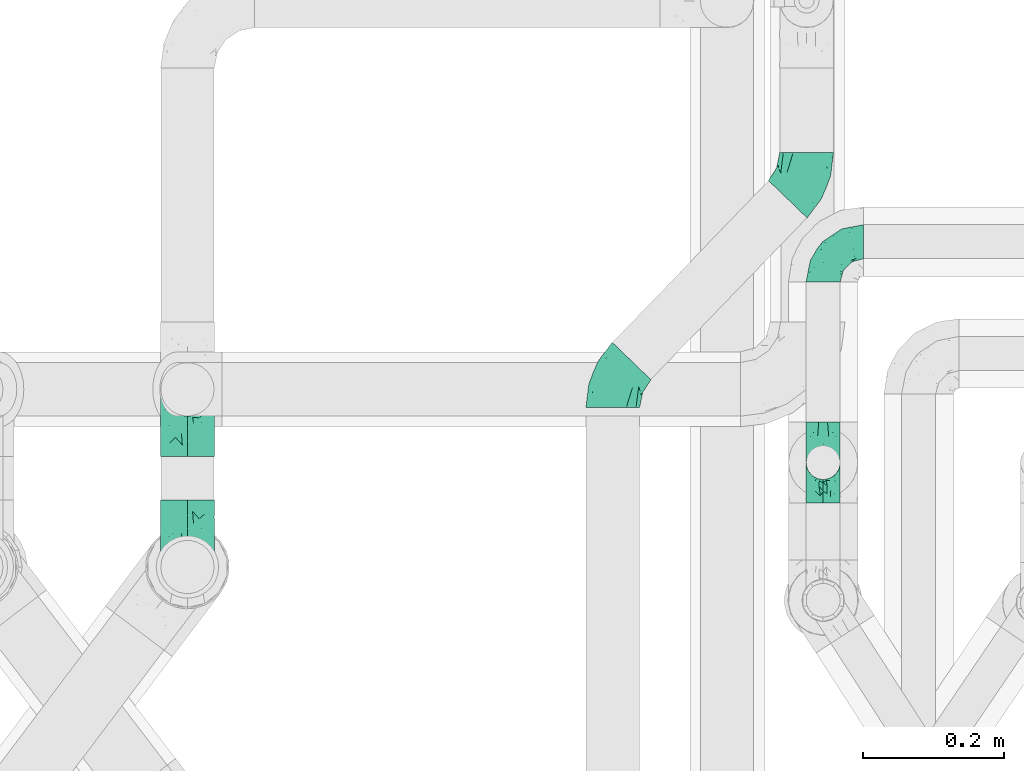
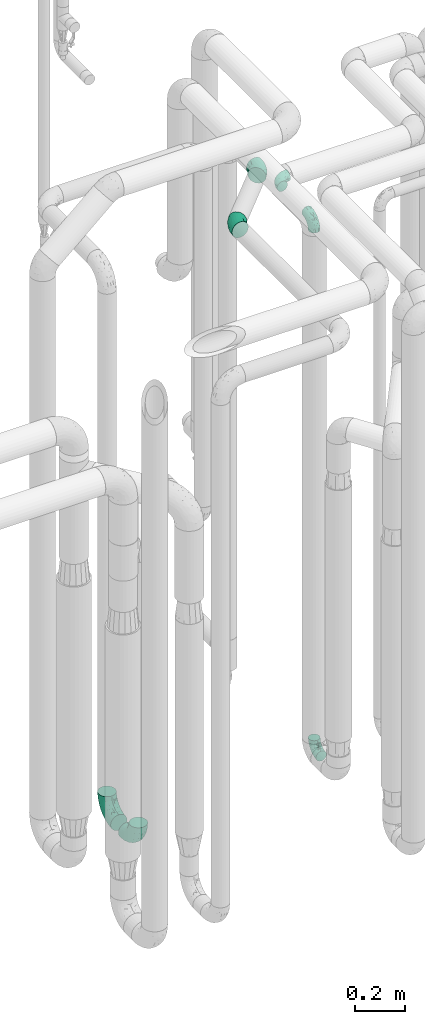
# One storey, part 670 of 824: 7 flow fittings.
"""IFC2X3 building model written with IfcOpenShell, lengths in millimetres."""

from ifc_helpers import new_model, entity, si_unit, converted_unit, derived_unit, direction, frame, origin, place, context, subcontext, project, spatial, faceted_brep, source, transform, mapped, material, type_object, type_shapes, element, save


model = new_model("IFC2X3")

# Units and contexts
model_context = context("Model", 3, precision=0.01, world=origin(), true_north=direction((6.12303176911189e-17, 1.0)))
body_context = subcontext(model_context, "Body", "Model", "MODEL_VIEW")
ifc_project = project(units=[si_unit("LENGTHUNIT", "METRE", prefix="MILLI"), si_unit("AREAUNIT", "SQUARE_METRE"), si_unit("VOLUMEUNIT", "CUBIC_METRE"), converted_unit("PLANEANGLEUNIT", "DEGREE", entity("IfcRatioMeasure", 0.0174532925199433), si_unit("PLANEANGLEUNIT", "RADIAN"), dimensions=[0, 0, 0, 0, 0, 0, 0]), si_unit("MASSUNIT", "GRAM", prefix="KILO"), derived_unit("MASSDENSITYUNIT", [(si_unit("MASSUNIT", "GRAM", prefix="KILO"), 1), (si_unit("LENGTHUNIT", "METRE"), -3)]), derived_unit("MOMENTOFINERTIAUNIT", [(si_unit("LENGTHUNIT", "METRE"), 4)]), si_unit("TIMEUNIT", "SECOND"), si_unit("FREQUENCYUNIT", "HERTZ"), si_unit("THERMODYNAMICTEMPERATUREUNIT", "DEGREE_CELSIUS"), derived_unit("THERMALTRANSMITTANCEUNIT", [(si_unit("MASSUNIT", "GRAM", prefix="KILO"), 1), (si_unit("THERMODYNAMICTEMPERATUREUNIT", "KELVIN"), -1), (si_unit("TIMEUNIT", "SECOND"), -3)]), derived_unit("VOLUMETRICFLOWRATEUNIT", [(si_unit("LENGTHUNIT", "METRE"), 3), (si_unit("TIMEUNIT", "SECOND"), -1)]), derived_unit("MASSFLOWRATEUNIT", [(si_unit("MASSUNIT", "GRAM", prefix="KILO"), 1), (si_unit("TIMEUNIT", "SECOND"), -1)]), derived_unit("ROTATIONALFREQUENCYUNIT", [(si_unit("TIMEUNIT", "SECOND"), -1)]), si_unit("ELECTRICCURRENTUNIT", "AMPERE"), si_unit("ELECTRICVOLTAGEUNIT", "VOLT"), si_unit("POWERUNIT", "WATT"), si_unit("FORCEUNIT", "NEWTON", prefix="KILO"), si_unit("ILLUMINANCEUNIT", "LUX"), si_unit("LUMINOUSFLUXUNIT", "LUMEN"), si_unit("LUMINOUSINTENSITYUNIT", "CANDELA"), derived_unit("USERDEFINED", [(si_unit("MASSUNIT", "GRAM", prefix="KILO"), -1), (si_unit("LENGTHUNIT", "METRE"), -2), (si_unit("TIMEUNIT", "SECOND"), 3), (si_unit("LUMINOUSFLUXUNIT", "LUMEN"), 1)]), derived_unit("LINEARVELOCITYUNIT", [(si_unit("LENGTHUNIT", "METRE"), 1), (si_unit("TIMEUNIT", "SECOND"), -1)]), si_unit("PRESSUREUNIT", "PASCAL"), derived_unit("USERDEFINED", [(si_unit("LENGTHUNIT", "METRE"), -2), (si_unit("MASSUNIT", "GRAM", prefix="KILO"), 1), (si_unit("TIMEUNIT", "SECOND"), -2)]), derived_unit("LINEARFORCEUNIT", [(si_unit("MASSUNIT", "GRAM", prefix="KILO"), 1), (si_unit("LENGTHUNIT", "METRE"), 1), (si_unit("TIMEUNIT", "SECOND"), -2), (si_unit("LENGTHUNIT", "METRE"), -1)]), derived_unit("PLANARFORCEUNIT", [(si_unit("MASSUNIT", "GRAM", prefix="KILO"), 1), (si_unit("LENGTHUNIT", "METRE"), 1), (si_unit("TIMEUNIT", "SECOND"), -2), (si_unit("LENGTHUNIT", "METRE"), -2)])], contexts=[model_context])

# Site, building, storey
site_placement = place(None, origin())
site = spatial("IfcSite", under=ifc_project, at=site_placement, CompositionType="ELEMENT")
building_placement = place(site_placement, origin())
building = spatial("IfcBuilding", under=site, at=building_placement, CompositionType="ELEMENT")
storey_placement = place(building_placement, frame((0.0, 0.0, 28200.0)))
storey = spatial("IfcBuildingStorey", under=building, at=storey_placement, CompositionType="ELEMENT", Elevation=28200.0)

# Flow fittings
ifc_material = material()
pipe_fitting_type_1 = type_object("IfcPipeFittingType", PredefinedType="NOTDEFINED", material=ifc_material)
shared_shape_1 = source(origin(), body_context, "Body", "Brep", [
    faceted_brep([(-57.0, 12.07, -20.91), (-57.0, 6.25, -23.33), (-57.0, 0.0, -24.15), (-57.0, -6.25, -23.33), (-57.0, -12.08, -20.91), (-57.0, -17.08, -17.08), (-57.0, -20.91, -12.08), (-57.0, -23.33, -6.25), (-57.0, -24.15, 0.0), (-57.0, -23.33, 6.25), (-57.0, -20.91, 12.07), (-57.0, -17.08, 17.08), (-57.0, -12.08, 20.91), (-57.0, -6.25, 23.33), (-57.0, 0.0, 24.15), (-57.0, 6.25, 23.33), (-57.0, 12.07, 20.91), (-57.0, 17.08, 17.08), (-57.0, 20.91, 12.07), (-57.0, 23.33, 6.25), (-57.0, 24.15, 0.0), (-57.0, 23.33, -6.25), (-57.0, 20.91, -12.08), (-57.0, 17.08, -17.08), (0.0, 57.0, -24.15), (-6.25, 57.0, -23.33), (-12.07, 57.0, -20.91), (-17.08, 57.0, -17.08), (-20.91, 57.0, -12.08), (-23.33, 57.0, -6.25), (-24.15, 57.0, 0.0), (-23.33, 57.0, 6.25), (-20.91, 57.0, 12.07), (-17.08, 57.0, 17.08), (-12.07, 57.0, 20.91), (-6.25, 57.0, 23.33), (0.0, 57.0, 24.15), (6.25, 57.0, 23.33), (12.08, 57.0, 20.91), (17.08, 57.0, 17.08), (20.91, 57.0, 12.07), (23.33, 57.0, 6.25), (24.15, 57.0, 0.0), (23.33, 57.0, -6.25), (20.91, 57.0, -12.08), (17.08, 57.0, -17.08), (12.08, 57.0, -20.91), (6.25, 57.0, -23.33), (14.9, 21.14, 6.17), (13.61, 24.64, 12.48), (6.23, 8.95, 8.98), (-41.47, -21.06, 0.0), (-41.92, -18.38, 13.72), (-24.64, -13.61, 12.48), (-37.37, -13.24, 18.15), (-6.8, -4.93, 8.18), (-21.76, -15.19, 6.22), (-12.78, -9.18, 0.0), (-37.73, -20.51, 7.75), (-7.38, 7.38, 20.24), (-23.37, -4.26, 20.42), (-11.9, -3.19, 15.86), (-42.14, -8.7, 21.82), (13.24, 37.37, 18.15), (9.33, 23.53, 16.85), (4.26, 23.37, 20.42), (2.77, 10.92, 15.55), (-29.46, 0.91, 23.52), (-44.13, 20.56, 15.69), (-39.25, 26.33, 10.88), (-49.02, 22.92, 9.96), (-34.58, 23.87, 17.15), (-15.8, 6.8, 22.81), (-8.67, 20.47, 23.88), (-18.12, 12.9, 24.08), (-48.29, 14.92, 19.65), (-44.06, -2.85, 23.78), (-9.23, 48.95, 22.58), (-3.78, 42.74, 24.07), (-40.34, 4.26, 24.09), (-44.02, 26.14, 5.46), (-44.04, 9.88, 22.74), (-4.95, 16.87, 22.52), (-2.75, 1.43, 12.5), (-25.48, 40.98, 10.71), (20.51, 37.73, 7.75), (18.38, 41.92, 13.72), (8.7, 42.14, 21.82), (-25.95, -17.97, 0.0), (2.85, 44.06, 23.78), (21.06, 41.47, 0.0), (17.97, 25.95, 0.0), (-24.04, -9.27, 17.13), (-33.26, 33.26, 5.86), (-28.55, 40.57, 0.0), (-40.57, 28.55, 0.0), (-25.29, 47.19, 4.06), (-27.01, 31.1, 16.77), (-15.7, 43.95, 19.9), (-20.27, 45.22, 15.61), (-30.53, 31.98, 12.64), (-11.28, 38.33, 22.92), (-9.97, 27.88, 24.09), (-20.15, 30.26, 21.25), (-31.25, 11.75, 23.64), (-28.75, 7.23, 24.15), (-29.53, 18.06, 22.27), (-28.44, 24.21, 20.02), (-37.55, 17.7, 20.26), (-15.88, 29.25, 22.99), (-20.82, 20.82, 23.44), (-0.91, 29.46, 23.52), (-13.5, -7.67, 12.04), (1.49, 1.56, 5.16), (8.86, 10.35, 4.59), (0.38, -0.38, 0.0), (9.18, 12.78, 0.0), (-37.37, -13.24, -18.15), (8.86, 10.35, -4.59), (-45.22, 20.27, -15.61), (-43.95, 15.7, -19.9), (-38.33, 11.28, -22.92), (-48.95, 9.23, -22.58), (-47.19, 25.29, -4.06), (-33.26, 33.26, -5.86), (18.38, 41.92, -13.72), (-30.26, 20.15, -21.25), (2.85, 44.06, -23.78), (-4.26, 40.34, -24.09), (-40.98, 25.48, -10.71), (-41.92, -18.38, -13.72), (9.25, 23.5, -16.92), (4.26, 23.37, -20.42), (13.24, 37.37, -18.15), (-37.73, -20.51, -7.75), (-11.75, 31.25, -23.64), (-7.23, 28.75, -24.15), (-12.9, 18.12, -24.08), (8.7, 42.14, -21.82), (-44.06, -2.85, -23.78), (-6.8, 15.8, -22.81), (-20.47, 8.67, -23.88), (-24.64, -13.61, -12.48), (-42.74, 3.78, -24.07), (-18.06, 29.53, -22.27), (-24.21, 28.44, -20.02), (-27.88, 9.97, -24.09), (-31.1, 27.01, -16.77), (-26.14, 44.02, -5.46), (14.9, 21.14, -6.17), (20.51, 37.73, -7.75), (-9.88, 44.04, -22.74), (-20.56, 44.13, -15.69), (-21.76, -15.19, -6.22), (-13.5, -7.67, -12.04), (-24.14, -9.76, -16.74), (-11.9, -3.19, -15.86), (-14.92, 48.29, -19.65), (-23.37, -4.26, -20.42), (-0.91, 29.46, -23.52), (-26.33, 39.25, -10.88), (-23.87, 34.58, -17.15), (-42.14, -8.7, -21.82), (-22.92, 49.02, -9.96), (13.61, 24.64, -12.48), (-31.98, 30.53, -12.64), (-16.87, 4.95, -22.52), (-17.7, 37.55, -20.26), (-29.25, 15.88, -22.99), (-20.82, 20.82, -23.44), (-29.46, 0.91, -23.52), (-7.38, 7.38, -20.24), (2.77, 10.92, -15.55), (6.23, 8.95, -8.98), (-6.8, -4.93, -8.18), (-2.81, 1.41, -12.54), (1.49, 1.56, -5.16)], [[[0, 1, 2, 3, 4, 5, 6, 7, 8, 9, 10, 11, 12, 13, 14, 15, 16, 17, 18, 19, 20, 21, 22, 23]], [[24, 25, 26, 27, 28, 29, 30, 31, 32, 33, 34, 35, 36, 37, 38, 39, 40, 41, 42, 43, 44, 45, 46, 47]], [[48, 49, 50]], [[9, 8, 51]], [[52, 53, 54]], [[55, 56, 57]], [[10, 58, 52]], [[9, 58, 10]], [[59, 60, 61]], [[54, 12, 11]], [[54, 62, 12]], [[63, 39, 38]], [[64, 65, 66]], [[62, 60, 67]], [[68, 69, 70]], [[71, 69, 68]], [[72, 73, 74]], [[16, 75, 17]], [[13, 76, 14]], [[35, 77, 78]], [[14, 79, 15]], [[17, 68, 18]], [[14, 76, 79]], [[20, 19, 80]], [[70, 19, 18]], [[81, 15, 79]], [[15, 81, 16]], [[73, 72, 82]], [[66, 83, 50]], [[32, 31, 84]], [[85, 86, 49]], [[63, 87, 65]], [[56, 58, 88]], [[36, 89, 37]], [[85, 41, 40]], [[36, 35, 78]], [[90, 41, 85]], [[40, 39, 86]], [[12, 62, 13]], [[86, 85, 40]], [[48, 85, 49]], [[85, 91, 90]], [[87, 38, 37]], [[92, 60, 54]], [[80, 69, 93]], [[93, 94, 95]], [[10, 52, 11]], [[94, 96, 30]], [[97, 98, 99]], [[80, 93, 95]], [[100, 97, 84]], [[99, 98, 33]], [[101, 102, 78]], [[103, 101, 98]], [[96, 31, 30]], [[77, 98, 101]], [[77, 35, 34]], [[34, 33, 98]], [[9, 51, 58]], [[87, 63, 38]], [[104, 105, 74]], [[106, 103, 107]], [[106, 81, 104]], [[75, 68, 17]], [[108, 107, 71]], [[33, 32, 99]], [[109, 103, 110]], [[101, 109, 102]], [[89, 78, 111]], [[53, 52, 58]], [[54, 11, 52]], [[60, 62, 54]], [[88, 58, 51]], [[76, 62, 67]], [[53, 112, 92]], [[60, 59, 72]], [[39, 63, 86]], [[49, 86, 63]], [[89, 87, 37]], [[42, 41, 90]], [[111, 82, 65]], [[111, 65, 87]], [[65, 59, 66]], [[104, 81, 79]], [[75, 81, 108]], [[32, 84, 99]], [[97, 99, 84]], [[98, 97, 103]], [[106, 107, 108]], [[74, 102, 110]], [[111, 78, 102]], [[74, 110, 104]], [[74, 67, 72]], [[61, 92, 112]], [[66, 59, 61]], [[56, 53, 58]], [[66, 50, 49]], [[61, 112, 83]], [[66, 49, 64]], [[78, 89, 36]], [[87, 89, 111]], [[62, 76, 13]], [[79, 76, 67]], [[100, 93, 69]], [[96, 93, 84]], [[55, 113, 50]], [[113, 114, 50]], [[104, 79, 105]], [[106, 104, 110]], [[20, 80, 95]], [[85, 48, 91]], [[115, 114, 113]], [[116, 91, 48]], [[70, 80, 19]], [[93, 96, 94]], [[84, 31, 96]], [[103, 106, 110]], [[81, 106, 108]], [[103, 97, 107]], [[71, 107, 97]], [[71, 97, 100]], [[108, 71, 68]], [[79, 67, 105]], [[67, 74, 105]], [[115, 113, 57]], [[112, 56, 55]], [[56, 88, 57]], [[60, 72, 67]], [[82, 72, 59]], [[65, 82, 59]], [[82, 111, 73]], [[111, 102, 73]], [[102, 74, 73]], [[81, 75, 16]], [[68, 75, 108]], [[68, 70, 18]], [[80, 70, 69]], [[98, 77, 34]], [[78, 77, 101]], [[93, 100, 84]], [[71, 100, 69]], [[102, 109, 110]], [[101, 103, 109]], [[53, 92, 54]], [[61, 60, 92]], [[56, 112, 53]], [[83, 112, 55]], [[50, 83, 55]], [[61, 83, 66]], [[49, 63, 64]], [[65, 64, 63]], [[57, 113, 55]], [[114, 115, 116]], [[116, 48, 114]], [[48, 50, 114]], [[117, 5, 4]], [[116, 115, 118]], [[119, 120, 23]], [[121, 122, 120]], [[95, 123, 20]], [[0, 23, 120]], [[124, 95, 94]], [[125, 45, 44]], [[121, 120, 126]], [[24, 127, 128]], [[22, 21, 129]], [[0, 122, 1]], [[5, 117, 130]], [[131, 132, 133]], [[134, 88, 51]], [[135, 136, 137]], [[6, 5, 130]], [[46, 138, 47]], [[139, 3, 2]], [[140, 141, 137]], [[6, 134, 7]], [[134, 130, 142]], [[143, 2, 1]], [[144, 126, 145]], [[121, 146, 143]], [[147, 120, 119]], [[94, 148, 124]], [[149, 150, 91]], [[30, 29, 148]], [[151, 25, 128]], [[27, 152, 28]], [[134, 153, 88]], [[154, 155, 156]], [[27, 26, 157]], [[151, 26, 25]], [[155, 158, 156]], [[24, 47, 127]], [[1, 122, 143]], [[138, 132, 159]], [[160, 152, 161]], [[24, 128, 25]], [[46, 133, 138]], [[162, 117, 4]], [[148, 160, 124]], [[152, 160, 163]], [[154, 142, 155]], [[45, 125, 133]], [[133, 46, 45]], [[125, 164, 133]], [[51, 7, 134]], [[42, 90, 43]], [[165, 147, 129]], [[153, 134, 142]], [[43, 150, 44]], [[162, 4, 3]], [[141, 140, 166]], [[117, 162, 158]], [[163, 29, 28]], [[43, 90, 150]], [[123, 21, 20]], [[144, 151, 135]], [[157, 152, 27]], [[167, 145, 161]], [[23, 22, 119]], [[168, 126, 169]], [[121, 168, 146]], [[139, 143, 170]], [[142, 130, 117]], [[8, 7, 51]], [[134, 6, 130]], [[139, 162, 3]], [[170, 166, 158]], [[170, 158, 162]], [[158, 171, 156]], [[44, 150, 125]], [[91, 150, 90]], [[164, 125, 150]], [[132, 138, 133]], [[127, 138, 159]], [[131, 164, 172]], [[132, 171, 140]], [[135, 151, 128]], [[157, 151, 167]], [[22, 129, 119]], [[147, 119, 129]], [[120, 147, 126]], [[144, 145, 167]], [[137, 146, 169]], [[170, 143, 146]], [[137, 169, 135]], [[137, 159, 140]], [[171, 172, 156]], [[173, 174, 175]], [[156, 175, 154]], [[174, 57, 153]], [[132, 172, 171]], [[172, 164, 173]], [[143, 139, 2]], [[162, 139, 170]], [[138, 127, 47]], [[128, 127, 159]], [[165, 124, 160]], [[123, 124, 129]], [[149, 173, 164]], [[176, 174, 173]], [[135, 128, 136]], [[144, 135, 169]], [[150, 149, 164]], [[176, 118, 115]], [[149, 91, 116]], [[30, 148, 94]], [[163, 148, 29]], [[124, 123, 95]], [[129, 21, 123]], [[126, 144, 169]], [[151, 144, 167]], [[126, 147, 145]], [[161, 145, 147]], [[161, 147, 165]], [[167, 161, 152]], [[128, 159, 136]], [[159, 137, 136]], [[154, 153, 142]], [[132, 140, 159]], [[174, 176, 57]], [[57, 88, 153]], [[166, 140, 171]], [[158, 166, 171]], [[166, 170, 141]], [[170, 146, 141]], [[146, 137, 141]], [[151, 157, 26]], [[152, 157, 167]], [[152, 163, 28]], [[148, 163, 160]], [[120, 122, 0]], [[143, 122, 121]], [[124, 165, 129]], [[161, 165, 160]], [[146, 168, 169]], [[121, 126, 168]], [[142, 117, 155]], [[158, 155, 117]], [[175, 156, 172]], [[153, 154, 174]], [[173, 175, 172]], [[174, 154, 175]], [[164, 131, 133]], [[172, 132, 131]], [[176, 173, 118]], [[57, 176, 115]], [[173, 149, 118]], [[149, 116, 118]]]),
])
type_shapes(pipe_fitting_type_1, [shared_shape_1])
for number, where, z_axis, x_axis in (
    (1, (46692.79, 14434.53, 400.0), (-1.0, 0.0, 0.0), (0.0, 0.0, -1.0)),
    (2, (46692.79, 14434.53, 3000.0), (-1.0, 0.0, 0.0), (0.0, 0.0, 1.0)),
    (3, (46692.79, 14747.03, 3000.0), (0.0, 0.0, 1.0), (-1.0, 0.0, 0.0)),
):
    element("IfcFlowFitting", number, at=place(storey_placement, frame(where, z_axis=z_axis, x_axis=x_axis)), inside=storey, type_object=pipe_fitting_type_1, material=ifc_material, context=body_context, shape_type="MappedRepresentation", body=[
        mapped(shared_shape_1, transform((0.0, 0.0, 0.0), scale=1.0)),
    ])
pipe_fitting_type_2 = type_object("IfcPipeFittingType", PredefinedType="NOTDEFINED", material=ifc_material)
shared_shape_2 = source(origin(), body_context, "Body", "Brep", [
    faceted_brep([(-95.0, 19.02, -32.95), (-95.0, 9.85, -36.75), (-95.0, 0.0, -38.05), (-95.0, -9.85, -36.75), (-95.0, -19.03, -32.95), (-95.0, -26.91, -26.91), (-95.0, -32.95, -19.03), (-95.0, -36.75, -9.85), (-95.0, -38.05, 0.0), (-95.0, -36.75, 9.85), (-95.0, -32.95, 19.02), (-95.0, -26.91, 26.91), (-95.0, -19.03, 32.95), (-95.0, -9.85, 36.75), (-95.0, 0.0, 38.05), (-95.0, 9.85, 36.75), (-95.0, 19.02, 32.95), (-95.0, 26.91, 26.91), (-95.0, 32.95, 19.02), (-95.0, 36.75, 9.85), (-95.0, 38.05, 0.0), (-95.0, 36.75, -9.85), (-95.0, 32.95, -19.03), (-95.0, 26.91, -26.91), (0.0, 95.0, -38.05), (-9.85, 95.0, -36.75), (-19.02, 95.0, -32.95), (-26.91, 95.0, -26.91), (-32.95, 95.0, -19.03), (-36.75, 95.0, -9.85), (-38.05, 95.0, 0.0), (-36.75, 95.0, 9.85), (-32.95, 95.0, 19.02), (-26.91, 95.0, 26.91), (-19.02, 95.0, 32.95), (-9.85, 95.0, 36.75), (0.0, 95.0, 38.05), (9.85, 95.0, 36.75), (19.03, 95.0, 32.95), (26.91, 95.0, 26.91), (32.95, 95.0, 19.02), (36.75, 95.0, 9.85), (38.05, 95.0, 0.0), (36.75, 95.0, -9.85), (32.95, 95.0, -19.03), (26.91, 95.0, -26.91), (19.03, 95.0, -32.95), (9.85, 95.0, -36.75), (-7.99, -4.96, 6.3), (-0.92, 0.92, 0.0), (4.62, 8.1, 8.01), (-76.19, -35.57, 0.0), (-64.32, -32.32, 12.43), (20.51, 62.45, 28.68), (-60.56, -33.52, 0.0), (-70.4, -13.47, 34.42), (-39.61, -5.88, 32.32), (-49.6, 2.07, 37.1), (-70.34, -28.81, 21.71), (14.64, 40.81, 26.5), (5.88, 39.61, 32.32), (3.59, 20.77, 25.31), (-40.45, 68.06, 16.75), (-62.45, -20.51, 28.68), (-44.52, -26.87, 0.0), (-28.47, -20.22, 0.0), (-26.43, -17.83, 8.75), (-76.1, 39.63, 10.76), (-72.74, 37.58, 18.19), (-60.35, 46.18, 14.61), (-13.4, 13.4, 32.12), (-20.77, -3.59, 25.31), (-14.66, 81.47, 35.56), (-6.22, 71.26, 37.92), (-57.5, 42.48, 22.79), (-15.0, 34.74, 37.7), (-27.1, 12.08, 36.05), (-9.2, 28.81, 35.63), (-79.98, 23.7, 30.95), (-73.68, -4.3, 37.48), (-30.74, 21.67, 37.97), (-62.36, 47.59, 6.79), (-72.71, 32.83, 24.69), (-67.42, 7.02, 37.95), (-32.13, 75.27, 24.51), (-43.46, 51.47, 26.26), (-24.98, 73.15, 31.29), (20.59, 41.28, 19.85), (7.79, 16.09, 15.86), (-73.21, 42.39, 0.0), (-54.73, 54.73, 0.0), (-73.44, 15.79, 35.79), (-5.94, 4.32, 20.43), (28.81, 70.34, 21.71), (32.32, 64.32, 12.43), (-53.59, 26.2, 35.09), (-52.02, 19.31, 37.21), (21.38, 33.53, 10.34), (26.87, 44.52, 0.0), (-48.28, 12.14, 38.05), (4.3, 73.68, 37.48), (-44.08, -25.52, 12.79), (-41.28, -20.59, 19.85), (35.57, 76.19, 0.0), (-47.26, 54.3, 20.18), (-47.4, 61.99, 8.58), (-42.39, 73.21, 0.0), (-39.67, 78.86, 7.21), (-45.69, 36.84, 33.11), (-32.83, 50.13, 33.35), (13.47, 70.4, 34.42), (-18.25, 63.73, 36.07), (-40.63, -13.75, 27.22), (-16.63, 46.37, 37.95), (-53.47, 38.79, 28.59), (-26.07, 48.54, 36.15), (-34.51, 34.51, 36.86), (-2.07, 49.6, 37.1), (-22.79, -10.49, 19.23), (-61.73, 28.67, 31.87), (9.65, 14.7, 0.0), (20.22, 28.47, 0.0), (33.52, 60.56, 0.0), (-11.42, -5.44, 13.25), (-14.7, -9.65, 0.0), (-81.47, 14.66, -35.56), (-62.45, -20.51, -28.68), (-71.26, 6.22, -37.92), (-75.27, 32.13, -24.51), (-73.15, 24.98, -31.29), (13.47, 70.4, -34.42), (5.88, 39.61, -32.32), (-2.07, 49.6, -37.1), (-78.86, 39.67, -7.21), (-70.4, -13.47, -34.42), (-39.61, -5.88, -32.32), (-61.99, 47.4, -8.58), (32.32, 64.32, -12.43), (28.81, 70.34, -21.71), (-63.73, 18.25, -36.07), (-50.13, 32.83, -33.35), (4.3, 73.68, -37.48), (-7.02, 67.42, -37.95), (-39.63, 76.1, -10.76), (-46.18, 60.35, -14.61), (-47.59, 62.36, -6.79), (-64.32, -32.32, -12.43), (-26.2, 53.59, -35.09), (-15.79, 73.44, -35.79), (-19.31, 52.02, -37.21), (-37.58, 72.74, -18.19), (-70.34, -28.81, -21.71), (-42.48, 57.5, -22.79), (-38.79, 53.47, -28.59), (-51.47, 43.46, -26.26), (-32.83, 72.71, -24.69), (-46.37, 16.63, -37.95), (-73.68, -4.3, -37.48), (-41.28, -20.59, -19.85), (-44.08, -25.52, -12.79), (13.75, 40.63, -27.22), (20.51, 62.45, -28.68), (-68.06, 40.45, -16.75), (-54.3, 47.26, -20.18), (-12.14, 48.28, -38.05), (-21.67, 30.74, -37.97), (-36.84, 45.69, -33.11), (-11.42, -5.44, -13.25), (7.79, 16.09, -15.86), (4.62, 8.1, -8.01), (-23.7, 79.98, -30.95), (-26.43, -17.83, -8.75), (-7.99, -4.96, -6.3), (-40.81, -14.64, -26.5), (-20.77, -3.59, -25.31), (-34.74, 15.0, -37.7), (-12.08, 27.1, -36.05), (-28.81, 9.2, -35.63), (-22.79, -10.49, -19.23), (21.38, 33.53, -10.34), (20.59, 41.28, -19.85), (-48.54, 26.07, -36.15), (-49.6, 2.07, -37.1), (-13.4, 13.4, -32.12), (3.59, 20.77, -25.31), (-28.67, 61.73, -31.87), (-34.51, 34.51, -36.86), (-5.94, 4.32, -20.43)], [[[0, 1, 2, 3, 4, 5, 6, 7, 8, 9, 10, 11, 12, 13, 14, 15, 16, 17, 18, 19, 20, 21, 22, 23]], [[24, 25, 26, 27, 28, 29, 30, 31, 32, 33, 34, 35, 36, 37, 38, 39, 40, 41, 42, 43, 44, 45, 46, 47]], [[48, 49, 50]], [[51, 52, 9]], [[53, 39, 38]], [[9, 52, 10]], [[54, 52, 51]], [[55, 56, 57]], [[11, 10, 58]], [[59, 60, 61]], [[32, 31, 62]], [[63, 12, 11]], [[63, 55, 12]], [[64, 65, 66]], [[67, 68, 69]], [[70, 56, 71]], [[35, 72, 73]], [[69, 68, 74]], [[75, 76, 77]], [[16, 78, 17]], [[13, 79, 14]], [[76, 75, 80]], [[67, 69, 81]], [[18, 17, 82]], [[14, 79, 83]], [[20, 19, 67]], [[84, 85, 86]], [[87, 61, 88]], [[89, 81, 90]], [[18, 82, 68]], [[15, 91, 16]], [[14, 83, 15]], [[71, 92, 61]], [[17, 78, 82]], [[93, 87, 94]], [[95, 91, 96]], [[97, 98, 94]], [[86, 72, 34]], [[96, 99, 80]], [[37, 36, 100]], [[40, 39, 93]], [[40, 94, 41]], [[64, 66, 101]], [[93, 94, 40]], [[58, 102, 63]], [[94, 103, 41]], [[94, 87, 97]], [[104, 69, 74]], [[34, 33, 86]], [[105, 69, 104]], [[52, 58, 10]], [[106, 107, 30]], [[108, 109, 85]], [[105, 106, 90]], [[53, 110, 60]], [[86, 111, 72]], [[86, 109, 111]], [[33, 84, 86]], [[12, 55, 13]], [[112, 56, 63]], [[110, 38, 37]], [[34, 72, 35]], [[36, 35, 73]], [[111, 113, 73]], [[105, 107, 106]], [[110, 53, 38]], [[74, 114, 85]], [[91, 15, 83]], [[105, 90, 81]], [[107, 62, 31]], [[33, 32, 84]], [[115, 109, 116]], [[111, 115, 113]], [[100, 73, 117]], [[56, 55, 63]], [[79, 55, 57]], [[102, 118, 112]], [[56, 70, 76]], [[100, 110, 37]], [[117, 77, 60]], [[117, 60, 110]], [[60, 70, 61]], [[58, 52, 101]], [[63, 11, 58]], [[39, 53, 93]], [[87, 93, 53]], [[96, 91, 83]], [[78, 91, 119]], [[32, 62, 84]], [[84, 62, 104]], [[86, 85, 109]], [[85, 114, 108]], [[80, 113, 116]], [[117, 73, 113]], [[80, 116, 96]], [[80, 57, 76]], [[71, 112, 118]], [[61, 87, 59]], [[62, 107, 105]], [[97, 120, 121]], [[70, 71, 61]], [[71, 118, 92]], [[73, 100, 36]], [[110, 100, 117]], [[55, 79, 13]], [[83, 79, 57]], [[96, 83, 99]], [[116, 108, 95]], [[50, 97, 88]], [[97, 87, 88]], [[50, 49, 120]], [[122, 94, 98]], [[89, 20, 67]], [[105, 81, 69]], [[89, 67, 81]], [[68, 19, 18]], [[68, 67, 19]], [[74, 68, 82]], [[114, 82, 119]], [[74, 85, 104]], [[82, 114, 74]], [[114, 119, 108]], [[95, 108, 119]], [[116, 109, 108]], [[123, 48, 50]], [[97, 50, 120]], [[123, 50, 88]], [[91, 95, 119]], [[116, 95, 96]], [[84, 104, 85]], [[104, 62, 105]], [[83, 57, 99]], [[57, 80, 99]], [[66, 48, 123]], [[66, 124, 48]], [[118, 66, 123]], [[124, 66, 65]], [[66, 118, 101]], [[54, 64, 52]], [[124, 49, 48]], [[30, 107, 31]], [[91, 78, 16]], [[82, 78, 119]], [[56, 76, 57]], [[77, 76, 70]], [[60, 77, 70]], [[77, 117, 75]], [[117, 113, 75]], [[113, 80, 75]], [[9, 8, 51]], [[103, 94, 122]], [[103, 42, 41]], [[73, 72, 111]], [[113, 115, 116]], [[111, 109, 115]], [[102, 112, 63]], [[71, 56, 112]], [[118, 102, 101]], [[92, 123, 88]], [[123, 92, 118]], [[61, 92, 88]], [[87, 53, 59]], [[60, 59, 53]], [[97, 121, 98]], [[58, 101, 102]], [[64, 101, 52]], [[125, 1, 0]], [[126, 5, 4]], [[2, 1, 127]], [[1, 125, 127]], [[128, 129, 23]], [[130, 131, 132]], [[89, 133, 20]], [[126, 134, 135]], [[136, 89, 90]], [[137, 138, 44]], [[139, 129, 140]], [[24, 141, 142]], [[143, 144, 145]], [[125, 129, 139]], [[6, 146, 7]], [[147, 148, 149]], [[146, 51, 7]], [[143, 150, 144]], [[146, 6, 151]], [[152, 153, 154]], [[126, 4, 134]], [[0, 23, 129]], [[28, 155, 150]], [[43, 42, 103]], [[54, 146, 64]], [[139, 156, 127]], [[157, 3, 2]], [[151, 158, 159]], [[160, 131, 161]], [[22, 21, 162]], [[136, 144, 163]], [[149, 164, 165]], [[24, 142, 25]], [[166, 140, 154]], [[154, 129, 128]], [[143, 30, 29]], [[167, 168, 169]], [[155, 28, 27]], [[26, 170, 27]], [[171, 167, 172]], [[26, 25, 148]], [[27, 170, 155]], [[173, 135, 174]], [[144, 150, 152]], [[175, 176, 177]], [[24, 47, 141]], [[45, 161, 46]], [[148, 25, 142]], [[176, 175, 165]], [[64, 159, 171]], [[138, 45, 44]], [[130, 46, 161]], [[137, 44, 43]], [[178, 159, 158]], [[137, 103, 122]], [[163, 144, 152]], [[136, 133, 89]], [[103, 137, 43]], [[6, 5, 151]], [[178, 158, 173]], [[134, 4, 3]], [[178, 173, 174]], [[137, 98, 179]], [[145, 90, 106]], [[138, 180, 161]], [[46, 130, 47]], [[136, 90, 145]], [[133, 162, 21]], [[23, 22, 128]], [[139, 140, 181]], [[139, 181, 156]], [[157, 127, 182]], [[157, 134, 3]], [[182, 177, 135]], [[182, 135, 134]], [[135, 183, 174]], [[131, 130, 161]], [[141, 130, 132]], [[160, 180, 184]], [[131, 183, 176]], [[5, 126, 151]], [[158, 151, 126]], [[180, 138, 137]], [[161, 45, 138]], [[149, 148, 142]], [[170, 148, 185]], [[22, 162, 128]], [[128, 162, 163]], [[129, 154, 140]], [[154, 153, 166]], [[165, 156, 186]], [[182, 127, 156]], [[165, 186, 149]], [[165, 132, 176]], [[131, 184, 183]], [[187, 167, 178]], [[184, 168, 187]], [[167, 169, 172]], [[184, 180, 168]], [[174, 183, 184]], [[127, 157, 2]], [[134, 157, 182]], [[130, 141, 47]], [[142, 141, 132]], [[149, 142, 164]], [[186, 166, 147]], [[180, 179, 168]], [[169, 179, 120]], [[137, 179, 180]], [[179, 121, 120]], [[106, 30, 143]], [[136, 145, 144]], [[106, 143, 145]], [[150, 29, 28]], [[150, 143, 29]], [[152, 150, 155]], [[153, 155, 185]], [[152, 154, 163]], [[155, 153, 152]], [[153, 185, 166]], [[147, 166, 185]], [[186, 140, 166]], [[169, 120, 49]], [[169, 49, 172]], [[179, 169, 168]], [[148, 147, 185]], [[186, 147, 149]], [[128, 163, 154]], [[163, 162, 136]], [[142, 132, 164]], [[132, 165, 164]], [[171, 124, 65]], [[124, 171, 172]], [[64, 146, 159]], [[171, 159, 178]], [[171, 65, 64]], [[172, 49, 124]], [[162, 133, 136]], [[20, 133, 21]], [[148, 170, 26]], [[155, 170, 185]], [[131, 176, 132]], [[177, 176, 183]], [[135, 177, 183]], [[177, 182, 175]], [[182, 156, 175]], [[156, 165, 175]], [[51, 146, 54]], [[51, 8, 7]], [[129, 125, 0]], [[127, 125, 139]], [[140, 186, 181]], [[156, 181, 186]], [[158, 126, 173]], [[135, 173, 126]], [[187, 178, 174]], [[171, 178, 167]], [[184, 187, 174]], [[167, 187, 168]], [[180, 160, 161]], [[184, 131, 160]], [[98, 137, 122]], [[98, 121, 179]], [[151, 159, 146]]]),
])
type_shapes(pipe_fitting_type_2, [shared_shape_2])
for number, where, z_axis, x_axis in (
    (4, (45793.07, 14538.08, 350.0), (-1.0, 0.0, 0.0), (0.0, 0.0, -1.0)),
    (5, (45793.07, 14286.62, 350.0), (-1.0, 0.0, 0.0), (0.0, -1.0, 0.0)),
):
    element("IfcFlowFitting", number, at=place(storey_placement, frame(where, z_axis=z_axis, x_axis=x_axis)), inside=storey, type_object=pipe_fitting_type_2, material=ifc_material, context=body_context, shape_type="MappedRepresentation", body=[
        mapped(shared_shape_2, transform((0.0, 0.0, 0.0), scale=1.0)),
    ])
pipe_fitting_type_3 = type_object("IfcPipeFittingType", PredefinedType="NOTDEFINED", material=ifc_material)
shared_shape_3 = source(origin(), body_context, "Body", "Brep", [
    faceted_brep([(-38.38, 19.02, -32.95), (-38.38, 9.85, -36.75), (-38.38, 0.0, -38.05), (-38.38, -9.85, -36.75), (-38.38, -19.03, -32.95), (-38.38, -26.91, -26.91), (-38.38, -32.95, -19.03), (-38.38, -36.75, -9.85), (-38.38, -38.05, 0.0), (-38.38, -36.75, 9.85), (-38.38, -32.95, 19.02), (-38.38, -26.91, 26.91), (-38.38, -19.03, 32.95), (-38.38, -9.85, 36.75), (-38.38, 0.0, 38.05), (-38.38, 9.85, 36.75), (-38.38, 19.02, 32.95), (-38.38, 26.91, 26.91), (-38.38, 32.95, 19.02), (-38.38, 36.75, 9.85), (-38.38, 38.05, 0.0), (-38.38, 36.75, -9.85), (-38.38, 32.95, -19.03), (-38.38, 26.91, -26.91), (20.77, 33.75, -36.75), (14.39, 40.35, -32.95), (8.92, 46.02, -26.91), (4.72, 50.37, -19.03), (2.08, 53.1, -9.85), (1.18, 54.03, 0.0), (2.08, 53.1, 9.85), (4.72, 50.37, 19.02), (8.92, 46.02, 26.91), (14.39, 40.35, 32.95), (20.77, 33.75, 36.75), (27.61, 26.66, 38.05), (34.45, 19.58, 36.75), (40.83, 12.98, 32.95), (46.3, 7.31, 26.91), (50.5, 2.96, 19.02), (53.14, 0.22, 9.85), (54.04, -0.71, 0.0), (53.14, 0.22, -9.85), (50.5, 2.96, -19.03), (46.3, 7.31, -26.91), (40.83, 12.98, -32.95), (34.45, 19.58, -36.75), (27.61, 26.66, -38.05), (-16.1, -28.69, 22.51), (-9.29, -32.27, 13.55), (8.9, -22.04, 21.74), (-19.56, -35.63, 0.0), (-4.69, -33.71, 0.0), (-12.93, -34.99, 6.7), (-10.8, -20.72, 29.56), (31.51, -9.45, 22.51), (5.49, -13.59, 30.96), (-19.25, -13.54, 34.88), (9.34, 20.78, 37.44), (-13.67, -2.83, 37.59), (-4.14, 10.25, 37.88), (-23.14, 5.66, 37.8), (22.16, -7.4, 29.56), (23.26, 3.63, 34.88), (-16.88, 16.63, 35.49), (-11.11, 27.51, 30.9), (-4.72, 36.0, 26.74), (10.35, -25.61, 14.72), (-19.03, 32.59, 23.84), (-15.82, 39.15, 15.48), (33.61, -16.18, 6.7), (38.82, -12.04, 0.0), (-12.9, 43.14, 7.91), (11.21, -27.75, 7.05), (11.97, 7.56, 37.59), (3.2, -7.92, 34.52), (29.1, -16.76, 13.55), (3.23, 25.33, 35.44), (-17.05, 42.2, 0.0), (11.05, -27.35, 0.0), (26.8, -20.99, 0.0), (-13.87, -2.87, -37.59), (-12.93, -34.99, -6.7), (11.15, -27.6, -7.86), (0.59, 23.68, -35.49), (-21.15, 8.46, -37.44), (-20.69, 39.99, -7.91), (-15.82, 39.15, -15.48), (22.16, -7.4, -29.56), (-21.62, 29.17, -26.74), (29.1, -16.76, -13.55), (-8.95, 36.66, -23.84), (11.8, 7.46, -37.59), (-19.92, 15.98, -35.44), (-9.29, -32.27, -13.55), (31.51, -9.45, -22.51), (-16.1, -28.69, -22.51), (8.9, -22.04, -21.74), (9.11, -25.93, -15.1), (-10.8, -20.72, -29.56), (5.49, -13.59, -30.96), (3.2, -7.92, -34.52), (23.26, 3.63, -34.88), (-19.25, -13.54, -34.88), (-11.11, 27.51, -30.9), (-4.14, 10.25, -37.88), (33.61, -16.18, -6.7), (12.71, 20.14, -37.8)], [[[0, 1, 2, 3, 4, 5, 6, 7, 8, 9, 10, 11, 12, 13, 14, 15, 16, 17, 18, 19, 20, 21, 22, 23]], [[24, 25, 26, 27, 28, 29, 30, 31, 32, 33, 34, 35, 36, 37, 38, 39, 40, 41, 42, 43, 44, 45, 46, 47]], [[48, 49, 50]], [[51, 52, 53]], [[12, 11, 54]], [[39, 38, 55]], [[54, 56, 57]], [[48, 11, 10]], [[34, 58, 35]], [[13, 12, 57]], [[59, 60, 61]], [[14, 13, 59]], [[62, 55, 38]], [[37, 36, 63]], [[61, 15, 14]], [[16, 64, 65]], [[9, 51, 53]], [[32, 66, 33]], [[49, 67, 50]], [[65, 17, 16]], [[18, 17, 68]], [[18, 68, 69]], [[19, 18, 69]], [[40, 70, 71]], [[72, 20, 19]], [[52, 73, 53]], [[49, 53, 73]], [[16, 15, 64]], [[74, 60, 59]], [[38, 37, 62]], [[75, 74, 59]], [[74, 36, 35]], [[66, 68, 65]], [[76, 39, 55]], [[77, 58, 34]], [[62, 37, 63]], [[17, 65, 68]], [[70, 40, 76]], [[49, 48, 10]], [[61, 64, 15]], [[56, 50, 62]], [[19, 69, 72]], [[10, 9, 49]], [[78, 72, 29]], [[48, 54, 11]], [[30, 72, 69]], [[75, 63, 74]], [[31, 69, 68]], [[55, 62, 50]], [[68, 66, 31]], [[57, 59, 13]], [[34, 33, 77]], [[77, 65, 64]], [[56, 75, 57]], [[74, 35, 58]], [[76, 40, 39]], [[54, 48, 50]], [[31, 30, 69]], [[76, 55, 50]], [[65, 77, 33]], [[60, 77, 64]], [[54, 57, 12]], [[59, 57, 75]], [[74, 63, 36]], [[63, 75, 56]], [[9, 8, 51]], [[73, 52, 79, 80]], [[9, 53, 49]], [[70, 73, 80]], [[73, 76, 67]], [[71, 70, 80]], [[71, 41, 40]], [[73, 70, 76]], [[77, 60, 58]], [[58, 60, 74]], [[59, 61, 14]], [[64, 61, 60]], [[73, 67, 49]], [[76, 50, 67]], [[29, 72, 30]], [[72, 78, 20]], [[50, 56, 54]], [[63, 56, 62]], [[33, 66, 65]], [[31, 66, 32]], [[3, 2, 81]], [[52, 82, 83]], [[25, 24, 84]], [[1, 85, 2]], [[21, 86, 87]], [[45, 44, 88]], [[0, 23, 89]], [[43, 42, 90]], [[91, 89, 22]], [[47, 46, 92]], [[28, 27, 87]], [[1, 0, 93]], [[82, 7, 94]], [[90, 95, 43]], [[96, 97, 98]], [[96, 94, 6]], [[5, 4, 99]], [[100, 101, 102]], [[7, 6, 94]], [[5, 96, 6]], [[103, 4, 3]], [[89, 91, 104]], [[99, 96, 5]], [[27, 26, 91]], [[20, 78, 86]], [[26, 104, 91]], [[29, 28, 86]], [[100, 97, 99]], [[104, 84, 93]], [[87, 22, 21]], [[27, 91, 87]], [[103, 99, 4]], [[84, 104, 25]], [[87, 91, 22]], [[105, 92, 81]], [[26, 25, 104]], [[42, 71, 106]], [[107, 24, 47]], [[102, 46, 45]], [[7, 82, 51]], [[43, 95, 44]], [[102, 88, 100]], [[95, 88, 44]], [[105, 107, 92]], [[97, 95, 90]], [[81, 2, 85]], [[106, 71, 80]], [[102, 92, 46]], [[101, 103, 81]], [[82, 94, 83]], [[101, 81, 92]], [[98, 90, 83]], [[107, 84, 24]], [[28, 87, 86]], [[93, 85, 1]], [[96, 99, 97]], [[88, 95, 97]], [[104, 93, 0]], [[105, 93, 84]], [[81, 103, 3]], [[103, 101, 100]], [[88, 102, 45]], [[92, 102, 101]], [[51, 82, 52]], [[51, 8, 7]], [[98, 83, 94]], [[106, 83, 90]], [[83, 80, 79, 52]], [[42, 41, 71]], [[83, 106, 80]], [[42, 106, 90]], [[93, 105, 85]], [[85, 105, 81]], [[92, 107, 47]], [[84, 107, 105]], [[20, 86, 21]], [[86, 78, 29]], [[97, 100, 88]], [[103, 100, 99]], [[0, 89, 104]], [[22, 89, 23]], [[96, 98, 94]], [[90, 98, 97]]]),
])
type_shapes(pipe_fitting_type_3, [shared_shape_3])
for number, where, z_axis, x_axis in (
    (6, (46395.03, 14550.58, 3000.0), (0.0, 0.0, 1.0), (-0.694658370459, -0.719339800338649, 0.0)),
    (7, (46669.38, 14834.67, 3000.0), (0.0, 0.0, 1.0), (0.694658370459026, 0.719339800338624, 0.0)),
):
    element("IfcFlowFitting", number, at=place(storey_placement, frame(where, z_axis=z_axis, x_axis=x_axis)), inside=storey, type_object=pipe_fitting_type_3, material=ifc_material, context=body_context, shape_type="MappedRepresentation", body=[
        mapped(shared_shape_3, transform((0.0, 0.0, 0.0), scale=1.0)),
    ])

save(model, "model.ifc")
